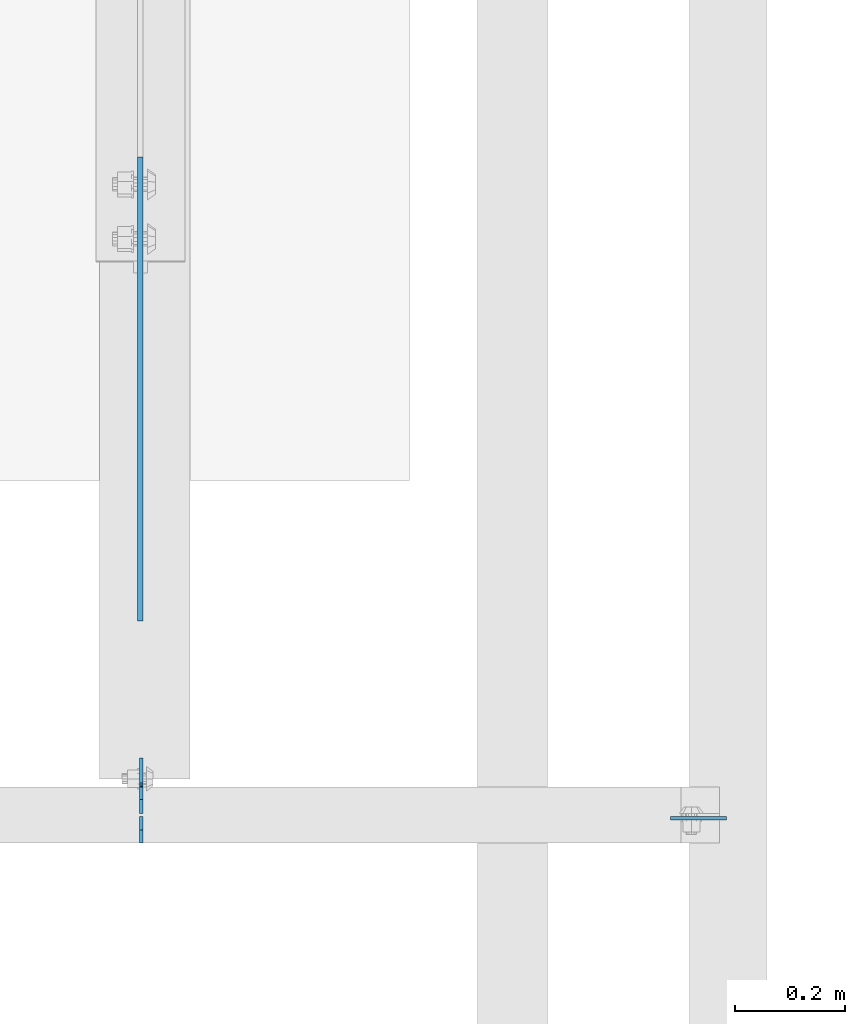
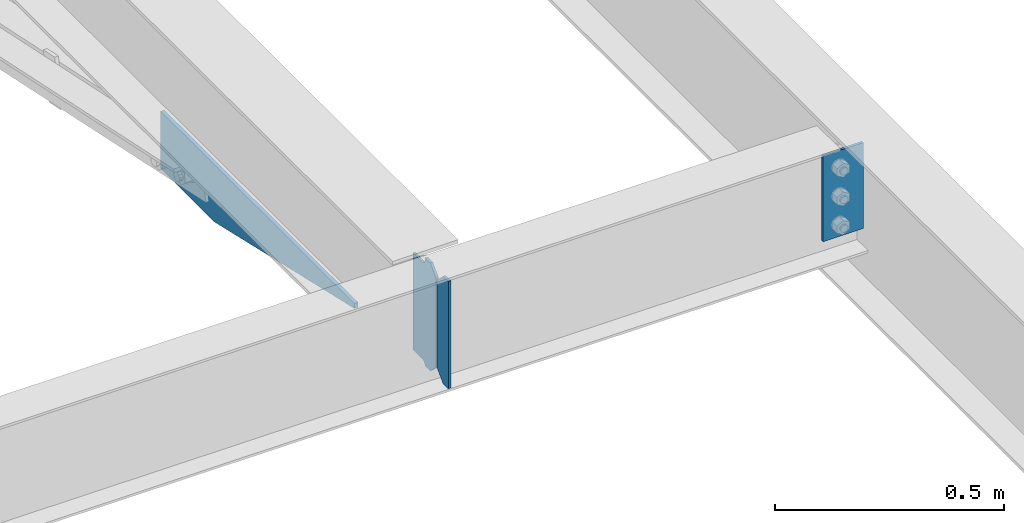
# One storey, part 1630 of 1763: 4 plates, 3 elements without a shape of their own.
"""IFC2X3 building model written with IfcOpenShell, lengths in millimetres."""

from ifc_helpers import new_model, si_unit, frame, origin_with_axes, place, context, subcontext, project, spatial, faceted_brep, material, type_object, element, aggregate, save


model = new_model("IFC2X3")

# Units and contexts
model_context = context("Model", 3, precision=1e-05, world=origin_with_axes())
body_context = subcontext(model_context, "Body", "Model", "MODEL_VIEW")
ifc_project = project(units=[si_unit("LENGTHUNIT", "METRE", prefix="MILLI"), si_unit("AREAUNIT", "SQUARE_METRE"), si_unit("VOLUMEUNIT", "CUBIC_METRE"), si_unit("MASSUNIT", "GRAM", prefix="KILO"), si_unit("TIMEUNIT", "SECOND"), si_unit("PLANEANGLEUNIT", "RADIAN"), si_unit("SOLIDANGLEUNIT", "STERADIAN"), si_unit("THERMODYNAMICTEMPERATUREUNIT", "DEGREE_CELSIUS"), si_unit("LUMINOUSINTENSITYUNIT", "LUMEN")], contexts=[model_context])

# Site, building, storey
site_placement = place(None, origin_with_axes())
site = spatial("IfcSite", under=ifc_project, at=site_placement, CompositionType="ELEMENT")
building_placement = place(site_placement, origin_with_axes())
building = spatial("IfcBuilding", under=site, at=building_placement, Name="Undefined", CompositionType="ELEMENT")
storey_placement = place(building_placement, origin_with_axes())
storey = spatial("IfcBuildingStorey", under=building, at=storey_placement, Name="Undefined", CompositionType="ELEMENT", Elevation=0.0)

# Assembly, plate
assembly_1_placement = place(storey_placement, origin_with_axes())
assembly_1 = element("IfcElementAssembly", 1, at=assembly_1_placement, inside=storey, Name="BEAM", AssemblyPlace="NOTDEFINED", PredefinedType="RIGID_FRAME")
ifc_material = material(Name="STEEL/A36")
plate_type_1 = type_object("IfcPlateType", PredefinedType="NOTDEFINED")
plate_1_placement = place(assembly_1_placement, frame((-48064.1747736984, 50880.5595338104, 4883.15), z_axis=(0.0, -1.0, 0.0), x_axis=(0.0, 0.0, -1.0)))
plate_1 = element("IfcPlate", 2, at=plate_1_placement, type_object=plate_type_1, material=ifc_material, Name="PLATE", context=body_context, shape_type="Brep", body=[
    faceted_brep([(0.0, -4.76249999999982, 0.0), (0.0, -4.76249999999709, 844.603210449219), (0.0, 4.76249999999709, 844.603210449219), (0.0, 4.76249999999982, 0.0), (12.6999998092651, -4.76249999999709, 844.603210449219), (12.6999998092651, 4.76249999999709, 844.603210449219), (152.399993896484, -4.76249999999709, 235.00325012207), (152.399993896484, 4.76249999999709, 235.00325012207), (152.400009155272, -4.76249999948777, 5.45696821063757e-12), (152.400009155273, 4.76250000051368, 3.63797880709171e-12)], [[[0, 1, 2, 3]], [[1, 4, 5, 2]], [[4, 6, 7, 5]], [[6, 8, 9, 7]], [[8, 0, 3, 9]], [[5, 7, 9, 3, 2]], [[8, 6, 4, 1, 0]]]),
])
aggregate(assembly_1, [plate_1])

assembly_2_placement = place(storey_placement, origin_with_axes())
assembly_2 = element("IfcElementAssembly", 3, at=assembly_2_placement, inside=storey, Name="BEAM", AssemblyPlace="NOTDEFINED", PredefinedType="RIGID_FRAME")
plate_type_2 = type_object("IfcPlateType", PredefinedType="NOTDEFINED")
plate_2_placement = place(assembly_2_placement, frame((-48062.587273746, 49684.78125, 4900.6125), z_axis=(0.0, 0.0, 1.0), x_axis=(0.0, 1.0, 0.0)))
plate_2 = element("IfcPlate", 4, at=plate_2_placement, type_object=plate_type_2, material=ifc_material, Name="PLATE", context=body_context, shape_type="Brep", body=[
    faceted_brep([(48.7345236062902, -3.17500000000291, 0.0), (48.7345236062902, 3.17500000000291, 0.0), (49.3854800386544, 3.17500000000291, 3.27257877585271), (49.3854800386544, -3.17500000000291, 3.27257877585271), (52.1384942519726, 3.17500000000291, 7.39275539271512), (52.1384942519726, -3.17500000000291, 7.39275539271512), (56.2586711318072, 3.17500000000291, 10.1457692124714), (56.2586711318072, -3.17500000000291, 10.1457692124714), (61.1187510223899, 3.17500000000291, 11.1124987868779), (61.1187510223899, -3.17500000000291, 11.1124987868779), (101.599998474121, -3.17500000000291, 11.1124949200548), (101.599998474121, 3.17500000000291, 11.1124949200548), (25.3999996184939, -3.17499999996653, 1.2732925824821e-11), (0.0, -3.17499999987194, 25.4000000001051), (0.0, 3.17500000014843, 25.4000000001197), (25.3999996185303, 3.17499995230901, 0.0), (0.0, -3.17500000000291, 261.937494277954), (0.0, 3.17500000000291, 261.937494277954), (25.3999996185303, -3.17500000000291, 287.337493896484), (25.3999996185303, 3.17500000000291, 287.337493896484), (48.4187500000044, -3.17500000000291, 287.337493896484), (48.4187500000044, 3.17500000000291, 287.337493896484), (48.4187500000044, -3.17500000000291, 280.987500572204), (48.4187500000044, 3.17500000000291, 280.987500572204), (49.3854799225956, -3.17500000000291, 276.127421054159), (49.3854799225956, 3.17500000000291, 276.127421054159), (52.1384938230694, -3.17500000000291, 272.007244586005), (52.1384938230694, 3.17500000000291, 272.007244586005), (56.2586702912231, -3.17500000000291, 269.254230685527), (56.2586702912231, 3.17500000000291, 269.254230685527), (61.1187498092695, -3.17500000000291, 268.287500762939), (61.1187498092695, 3.17500000000291, 268.287500762939), (101.599998474121, -3.17500000000291, 268.287500762939), (101.599998474121, 3.17500000000291, 268.287500762939)], [[[0, 1, 2, 3]], [[3, 2, 4, 5]], [[5, 4, 6, 7]], [[7, 6, 8, 9]], [[10, 9, 8, 11]], [[12, 13, 14, 15]], [[13, 16, 17, 14]], [[16, 18, 19, 17]], [[19, 18, 20, 21]], [[20, 22, 23, 21]], [[24, 25, 23, 22]], [[26, 27, 25, 24]], [[28, 29, 27, 26]], [[30, 31, 29, 28]], [[32, 33, 31, 30]], [[33, 32, 10, 11]], [[6, 4, 2, 1, 15, 14, 17, 19, 21, 23, 25, 27, 29, 31, 33, 11, 8]], [[12, 15, 1, 0]], [[32, 30, 28, 26, 24, 22, 20, 18, 16, 13, 12, 0, 3, 5, 7, 9, 10]]]),
])

assembly_3_placement = place(storey_placement, origin_with_axes())
assembly_3 = element("IfcElementAssembly", 5, at=assembly_3_placement, inside=storey, Name="BEAM", AssemblyPlace="NOTDEFINED", PredefinedType="RIGID_FRAME")
plate_3_placement = place(assembly_3_placement, frame((-46996.8456070317, 49676.84375, 5156.2), z_axis=(-1.0, 0.0, 0.0), x_axis=(0.0, 0.0, -1.0)))
plate_3 = element("IfcPlate", 6, at=plate_3_placement, type_object=plate_type_2, material=ifc_material, Name="PLATE", context=body_context, shape_type="Brep", body=[
    faceted_brep([(1.81898940354586e-12, -3.17500000000291, 0.0), (0.0, -3.17499999999927, 101.599998474121), (0.0, 3.17499999999927, 101.599998474121), (-1.81898940354586e-12, 3.17499999997381, 0.0), (228.600006103516, -3.17499999999927, 101.599998474121), (228.600006103516, 3.17499999999927, 101.599998474121), (228.600006103516, -3.17500000001019, -7.27595761418343e-12), (228.600006103516, 3.17499999999563, -7.27595761418343e-12)], [[[0, 1, 2, 3]], [[1, 4, 5, 2]], [[4, 6, 7, 5]], [[6, 0, 3, 7]], [[5, 7, 3, 2]], [[6, 4, 1, 0]]]),
])
aggregate(assembly_3, [plate_3])

# Plate
plate_type_3 = type_object("IfcPlateType", PredefinedType="NOTDEFINED")
plate_4_placement = place(assembly_2_placement, frame((-48062.587273746, 49680.01875, 4900.6125), z_axis=(0.0, 0.0, 1.0), x_axis=(0.0, -1.0, 0.0)))
plate_4 = element("IfcPlate", 7, at=plate_4_placement, type_object=plate_type_3, material=ifc_material, Name="PLATE", context=body_context, shape_type="Brep", body=[
    faceted_brep([(0.0, -3.17499999987194, 25.4000000001051), (0.0, -3.17500000000291, 260.35000038147), (0.0, 3.17500000000291, 260.35000038147), (0.0, 3.17500000014843, 25.4000000001197), (25.3999996185303, -3.17500000000291, 285.75), (25.3999996185303, 3.17500000000291, 285.75), (48.4187507629395, -3.17500000000291, 285.75), (48.4187507629395, 3.17500000000291, 285.75), (48.4187507629395, -3.17500000000291, 0.0), (48.4187507629395, 3.17500000000291, 0.0), (25.3999996184939, -3.17499999996653, 1.2732925824821e-11), (25.3999996185303, 3.17499995230901, 0.0)], [[[0, 1, 2, 3]], [[1, 4, 5, 2]], [[4, 6, 7, 5]], [[6, 8, 9, 7]], [[8, 10, 11, 9]], [[10, 0, 3, 11]], [[5, 7, 9, 11, 3, 2]], [[10, 8, 6, 4, 1, 0]]]),
])

aggregate(assembly_2, [plate_4, plate_2])

save(model, "model.ifc")
